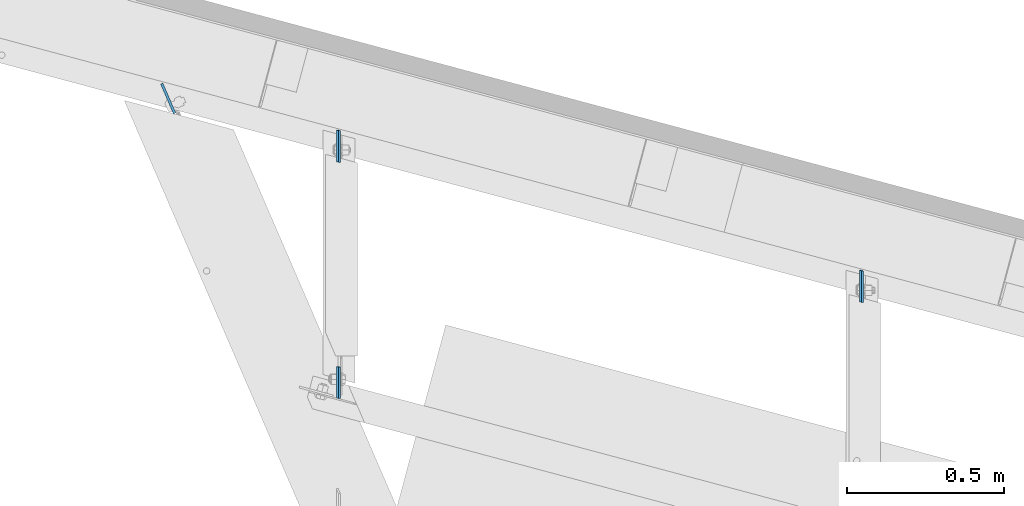
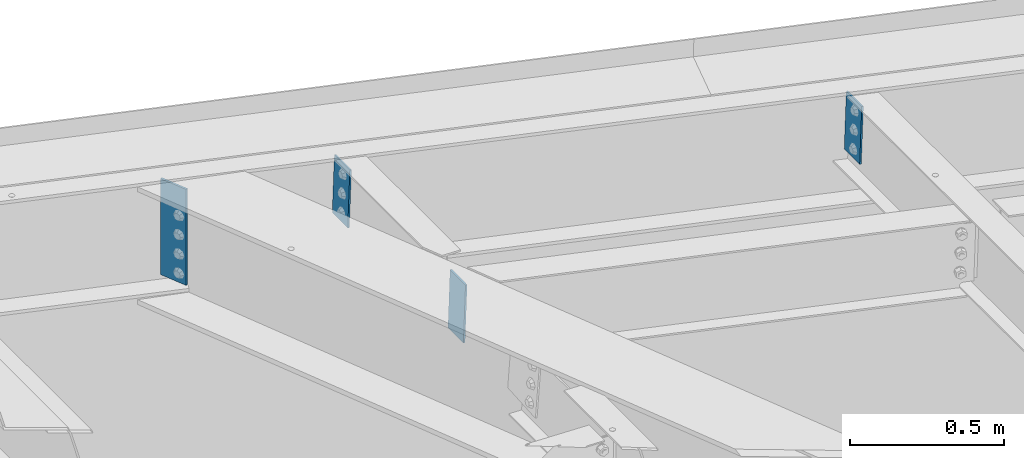
# One storey, part 1667 of 1763: 4 plates, 2 elements without a shape of their own.
"""IFC2X3 building model written with IfcOpenShell, lengths in millimetres."""

from ifc_helpers import new_model, si_unit, frame, origin_with_axes, place, context, subcontext, project, spatial, faceted_brep, material, type_object, element, aggregate, save


model = new_model("IFC2X3")

# Units and contexts
model_context = context("Model", 3, precision=1e-05, world=origin_with_axes())
body_context = subcontext(model_context, "Body", "Model", "MODEL_VIEW")
ifc_project = project(units=[si_unit("LENGTHUNIT", "METRE", prefix="MILLI"), si_unit("AREAUNIT", "SQUARE_METRE"), si_unit("VOLUMEUNIT", "CUBIC_METRE"), si_unit("MASSUNIT", "GRAM", prefix="KILO"), si_unit("TIMEUNIT", "SECOND"), si_unit("PLANEANGLEUNIT", "RADIAN"), si_unit("SOLIDANGLEUNIT", "STERADIAN"), si_unit("THERMODYNAMICTEMPERATUREUNIT", "DEGREE_CELSIUS"), si_unit("LUMINOUSINTENSITYUNIT", "LUMEN")], contexts=[model_context])

# Site, building, storey
site_placement = place(None, origin_with_axes())
site = spatial("IfcSite", under=ifc_project, at=site_placement, CompositionType="ELEMENT")
building_placement = place(site_placement, origin_with_axes())
building = spatial("IfcBuilding", under=site, at=building_placement, Name="Undefined", CompositionType="ELEMENT")
storey_placement = place(building_placement, origin_with_axes())
storey = spatial("IfcBuildingStorey", under=building, at=storey_placement, Name="Undefined", CompositionType="ELEMENT", Elevation=0.0)

# Assembly, plate
assembly_1_placement = place(storey_placement, origin_with_axes())
assembly_1 = element("IfcElementAssembly", 1, at=assembly_1_placement, inside=storey, Name="BEAM", AssemblyPlace="NOTDEFINED", PredefinedType="RIGID_FRAME")
ifc_material = material(Name="STEEL/A36")
plate_type_1 = type_object("IfcPlateType", PredefinedType="NOTDEFINED")
plate_1_placement = place(assembly_1_placement, frame((-48008.5912489182, 68918.4234811865, 12663.603370281), z_axis=(0.000232169974769931, 0.999968895633207, 0.00788377214322279), x_axis=(-0.0294353940016984, 0.00788719000046239, -0.999535567057952)))
plate_1 = element("IfcPlate", 2, at=plate_1_placement, type_object=plate_type_1, material=ifc_material, Name="PLATE", context=body_context, shape_type="Brep", body=[
    faceted_brep([(1.81898940354586e-12, -3.17500000000291, 0.0), (0.0, -3.17499999982829, 100.460510253775), (0.0, 3.17500000019209, 100.460510253775), (-1.81898940354586e-12, 3.17499999997381, 0.0), (228.600006103516, -3.17499999982829, 100.460510253775), (228.600006103516, 3.17500000019209, 100.460510253775), (228.600006103516, -3.17500000001019, -7.27595761418343e-12), (228.600006103516, 3.17499999999563, -7.27595761418343e-12)], [[[0, 1, 2, 3]], [[1, 4, 5, 2]], [[4, 6, 7, 5]], [[6, 0, 3, 7]], [[5, 7, 3, 2]], [[6, 4, 1, 0]]]),
])
aggregate(assembly_1, [plate_1])

# Assembly, plates
assembly_2_placement = place(storey_placement, origin_with_axes())
assembly_2 = element("IfcElementAssembly", 3, at=assembly_2_placement, inside=storey, Name="BEAM", AssemblyPlace="NOTDEFINED", PredefinedType="RIGID_FRAME")
plate_2_placement = place(assembly_2_placement, frame((-46343.5154788683, 69325.2821606479, 12604.7885584717), z_axis=(-0.000232170004186628, -0.99996889563321, -0.0078837721420914), x_axis=(-0.0294353940016984, 0.00788719000046239, -0.999535567057952)))
plate_2 = element("IfcPlate", 4, at=plate_2_placement, type_object=plate_type_1, material=ifc_material, Name="PLATE", context=body_context, shape_type="Brep", body=[
    faceted_brep([(1.81898940354586e-12, -3.17500000000291, 0.0), (0.0, -3.17499999982829, 100.460510253775), (0.0, 3.17500000019209, 100.460510253775), (-1.81898940354586e-12, 3.17499999997381, 0.0), (228.600006103516, -3.17499999982829, 100.460510253775), (228.600006103516, 3.17500000019209, 100.460510253775), (228.600006103516, -3.17500000001019, -7.27595761418343e-12), (228.600006103516, 3.17499999999563, -7.27595761418343e-12)], [[[0, 1, 2, 3]], [[1, 4, 5, 2]], [[4, 6, 7, 5]], [[6, 0, 3, 7]], [[5, 7, 3, 2]], [[6, 4, 1, 0]]]),
])
plate_3_placement = place(assembly_2_placement, frame((-48008.563096101, 69771.4303259714, 12664.5593528667), z_axis=(-0.000232170004186628, -0.99996889563321, -0.0078837721420914), x_axis=(-0.0294353940016984, 0.00788719000046239, -0.999535567057952)))
plate_3 = element("IfcPlate", 5, at=plate_3_placement, type_object=plate_type_1, material=ifc_material, Name="PLATE", context=body_context, shape_type="Brep", body=[
    faceted_brep([(1.81898940354586e-12, -3.17500000000291, 0.0), (0.0, -3.17499999982829, 100.460510253775), (0.0, 3.17500000019209, 100.460510253775), (-1.81898940354586e-12, 3.17499999997381, 0.0), (228.600006103516, -3.17499999982829, 100.460510253775), (228.600006103516, 3.17500000019209, 100.460510253775), (228.600006103516, -3.17500000001019, -7.27595761418343e-12), (228.600006103516, 3.17499999999563, -7.27595761418343e-12)], [[[0, 1, 2, 3]], [[1, 4, 5, 2]], [[4, 6, 7, 5]], [[6, 0, 3, 7]], [[5, 7, 3, 2]], [[6, 4, 1, 0]]]),
])
plate_type_2 = type_object("IfcPlateType", PredefinedType="NOTDEFINED")
plate_4_placement = place(assembly_2_placement, frame((-48575.0145351745, 69921.5092703976, 12678.004067883), z_axis=(0.396956490160615, -0.917837428371368, 0.0), x_axis=(0.0, 0.0, -1.0)))
plate_4 = element("IfcPlate", 6, at=plate_4_placement, type_object=plate_type_2, material=ifc_material, Name="PLATE", context=body_context, shape_type="Brep", body=[
    faceted_brep([(0.0, -3.96900000000096, 0.0), (8.73114913702011e-11, -3.96899999950256, 103.515136718343), (8.73114913702011e-11, 3.96900000051755, 103.515136718328), (0.0, 3.96900000000096, 0.0), (381.0, -3.96899999950256, 103.515136718343), (381.0, 3.96900000051755, 103.515136718328), (381.0, -3.96900000001915, 3.34694050252438e-10), (381.0, 3.9690000000046, 3.20142135024071e-10)], [[[0, 1, 2, 3]], [[1, 4, 5, 2]], [[4, 6, 7, 5]], [[6, 0, 3, 7]], [[5, 7, 3, 2]], [[6, 4, 1, 0]]]),
])
aggregate(assembly_2, [plate_4, plate_2, plate_3])

save(model, "model.ifc")
